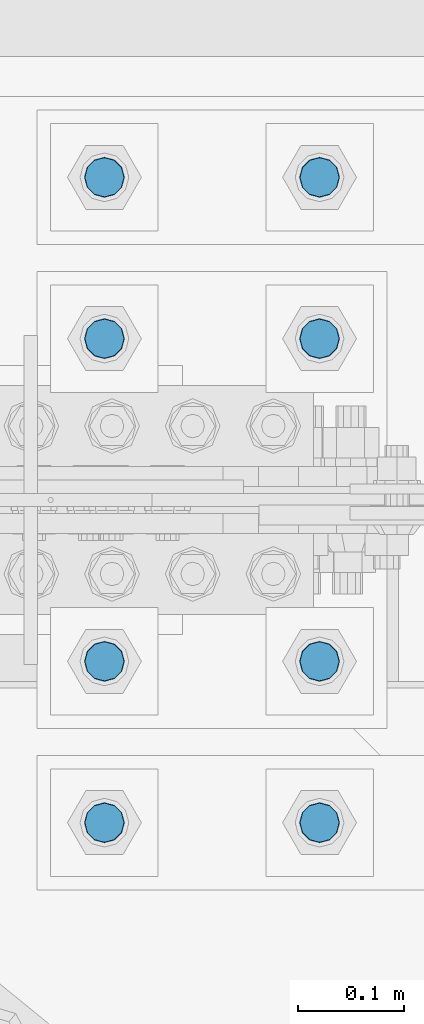
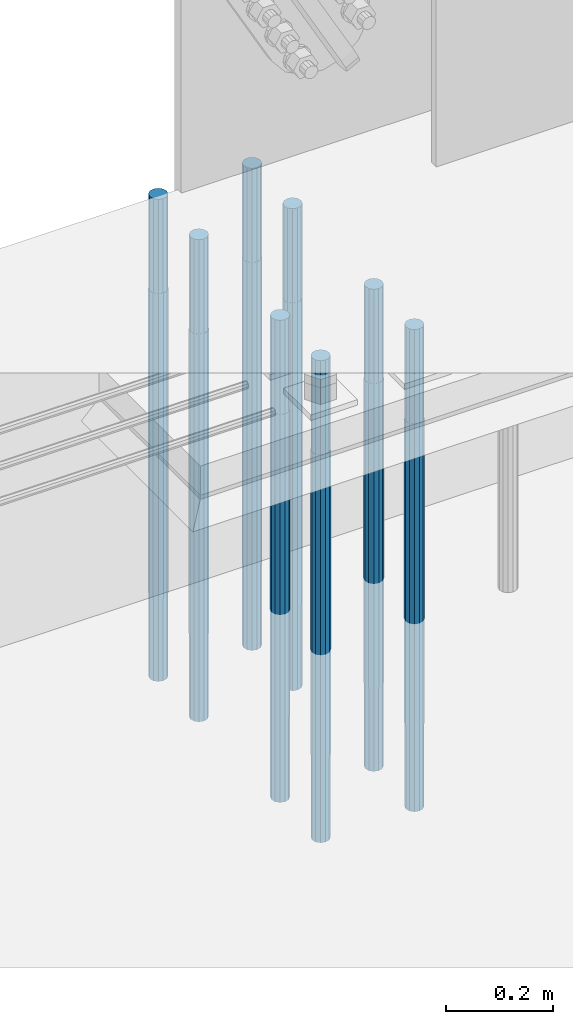
# One storey, part 1386 of 3843: 8 columns, 1 element without a shape of its own.
"""IFC2X3 building model written with IfcOpenShell, lengths in millimetres."""

from ifc_helpers import new_model, si_unit, frame, origin_with_axes, place, context, subcontext, project, spatial, faceted_brep, material, type_object, element, aggregate, save


model = new_model("IFC2X3")

# Units and contexts
model_context = context("Model", 3, precision=1e-05, world=origin_with_axes())
body_context = subcontext(model_context, "Body", "Model", "MODEL_VIEW")
ifc_project = project(units=[si_unit("LENGTHUNIT", "METRE", prefix="MILLI"), si_unit("AREAUNIT", "SQUARE_METRE"), si_unit("VOLUMEUNIT", "CUBIC_METRE"), si_unit("MASSUNIT", "GRAM", prefix="KILO"), si_unit("TIMEUNIT", "SECOND"), si_unit("PLANEANGLEUNIT", "RADIAN"), si_unit("SOLIDANGLEUNIT", "STERADIAN"), si_unit("THERMODYNAMICTEMPERATUREUNIT", "DEGREE_CELSIUS"), si_unit("LUMINOUSINTENSITYUNIT", "LUMEN")], contexts=[model_context])

# Site, building, storey
site_placement = place(None, origin_with_axes())
site = spatial("IfcSite", under=ifc_project, at=site_placement, CompositionType="ELEMENT")
building_placement = place(site_placement, origin_with_axes())
building = spatial("IfcBuilding", under=site, at=building_placement, Name="Undefined", CompositionType="ELEMENT")
storey_placement = place(building_placement, origin_with_axes())
storey = spatial("IfcBuildingStorey", under=building, at=storey_placement, Name="Undefined", CompositionType="ELEMENT", Elevation=0.0)

# Assembly, columns
assembly_placement = place(storey_placement, origin_with_axes())
assembly = element("IfcElementAssembly", 1, at=assembly_placement, inside=storey, Name="TEMPLATE", AssemblyPlace="NOTDEFINED", PredefinedType="RIGID_FRAME")
ifc_material = material(Name="Undefined/F1554-GR.55")
column_type = type_object("IfcColumnType", PredefinedType="NOTDEFINED")
column_1_placement = place(assembly_placement, frame((62128.4, 91909.9, 30022.8), z_axis=(0.0, -1.0, 0.0), x_axis=(0.0, 0.0, -1.0)))
column_1 = element("IfcColumn", 2, at=column_1_placement, type_object=column_type, material=ifc_material, Name="ANCHOR_ROD", context=body_context, shape_type="Brep", body=[
    faceted_brep([(-215.899999999998, -16.0214699700118, 9.25), (-215.899999999998, -9.25, 16.0214699700155), (-215.899999999998, 0.0, 18.5), (-215.899999999998, 9.25, 16.0214699700155), (-215.899999999998, 16.0214699700118, 9.25), (-215.899999999998, 18.5, 0.0), (-215.899999999998, 16.0214699700118, -9.25), (-215.899999999998, 9.25, -16.0214699700155), (-215.899999999998, 0.0, -18.5), (-215.899999999998, -9.25, -16.0214699700155), (-215.899999999998, -16.0214699700118, -9.25), (-215.899999999998, -18.5, 0.0), (0.0, 18.5, 0.0), (0.0, 16.0214699700118, -9.25), (0.0, 9.25, -16.0214699700155), (0.0, 0.0, -18.5), (0.0, -9.25, -16.0214699700155), (0.0, -16.0214699700118, -9.25), (0.0, -18.5, 0.0), (0.0, -16.0214699700118, 9.25), (0.0, -9.25, 16.0214699700155), (0.0, 0.0, 18.5), (0.0, 9.25, 16.0214699700155), (0.0, 16.0214699700118, 9.25), (0.0, -16.4977839420972, 9.52500000000146), (0.0, -9.52500000000146, 16.4977839420972), (0.0, 0.0, 19.0499989999989), (0.0, 9.52500000000146, 16.4977839420972), (0.0, 16.4977839420972, 9.52500000000146), (0.0, 19.0500000000029, 0.0), (0.0, 16.4977839420972, -9.52500000000146), (0.0, 9.52500000000146, -16.4977839420972), (0.0, 0.0, -19.0499989999989), (0.0, -9.52500000000146, -16.4977839420972), (0.0, -16.4977839420972, -9.52500000000146), (0.0, -19.0500000000029, 0.0), (698.5, -19.0499999999993, 0.0), (698.5, -16.4977839420935, 9.52499999999418), (698.5, -9.52500000000146, 16.4977839420899), (698.5, 0.0, 19.0500000000029), (698.5, 9.52500000000146, 16.4977839420899), (698.5, 16.4977839420935, 9.52499999999418), (698.5, 19.0499999999993, 0.0), (698.5, 16.4977839420935, -9.52499999999418), (698.5, 9.52500000000146, -16.4977839420899), (698.5, 0.0, -19.0500000000029), (698.5, -9.52500000000146, -16.4977839420899), (698.5, -16.4977839420935, -9.52499999999418), (698.5, -9.25, 16.0214699700155), (698.5, 0.0, 18.5), (698.5, 9.25, 16.0214699700155), (698.5, 16.0214699700118, 9.25), (698.5, 18.5, 0.0), (698.5, 16.0214699700118, -9.25), (698.5, 9.25, -16.0214699700155), (698.5, 0.0, -18.5), (698.5, -9.25, -16.0214699700155), (698.5, -16.0214699700118, -9.25), (698.5, -18.5, 0.0), (698.5, -16.0214699700118, 9.25), (889.0, -9.25, -16.0214699700155), (889.0, 0.0, -18.5), (889.0, 9.25, -16.0214699700155), (889.0, 16.0214699700118, -9.25), (889.0, 18.5, 0.0), (889.0, 16.0214699700118, 9.25), (889.0, 9.25, 16.0214699700155), (889.0, 0.0, 18.5), (889.0, -9.25, 16.0214699700155), (889.0, -16.0214699700118, 9.25), (889.0, -18.5, 0.0), (889.0, -16.0214699700118, -9.25)], [[[0, 1, 2, 3, 4, 5, 6, 7, 8, 9, 10, 11]], [[6, 5, 12, 13]], [[7, 6, 13, 14]], [[8, 7, 14, 15]], [[9, 8, 15, 16]], [[10, 9, 16, 17]], [[11, 10, 17, 18]], [[0, 11, 18, 19]], [[1, 0, 19, 20]], [[2, 1, 20, 21]], [[3, 2, 21, 22]], [[4, 3, 22, 23]], [[5, 4, 23, 12]], [[24, 25, 26, 27, 28, 29, 30, 31, 32, 33, 34, 35], [22, 21, 20, 19, 18, 17, 16, 15, 14, 13, 12, 23]], [[24, 35, 36, 37]], [[25, 24, 37, 38]], [[26, 25, 38, 39]], [[27, 26, 39, 40]], [[28, 27, 40, 41]], [[29, 28, 41, 42]], [[30, 29, 42, 43]], [[31, 30, 43, 44]], [[32, 31, 44, 45]], [[33, 32, 45, 46]], [[34, 33, 46, 47]], [[35, 34, 47, 36]], [[46, 45, 44, 43, 42, 41, 40, 39, 38, 37, 36, 47], [48, 49, 50, 51, 52, 53, 54, 55, 56, 57, 58, 59]], [[60, 61, 62, 63, 64, 65, 66, 67, 68, 69, 70, 71]], [[68, 67, 49, 48]], [[69, 68, 48, 59]], [[70, 69, 59, 58]], [[71, 70, 58, 57]], [[60, 71, 57, 56]], [[61, 60, 56, 55]], [[62, 61, 55, 54]], [[63, 62, 54, 53]], [[64, 63, 53, 52]], [[65, 64, 52, 51]], [[66, 65, 51, 50]], [[67, 66, 50, 49]]]),
])
column_2_placement = place(assembly_placement, frame((62331.6, 91909.9, 30022.8), z_axis=(0.0, -1.0, 0.0), x_axis=(0.0, 0.0, -1.0)))
column_2 = element("IfcColumn", 3, at=column_2_placement, type_object=column_type, material=ifc_material, Name="ANCHOR_ROD", context=body_context, shape_type="Brep", body=[
    faceted_brep([(-215.899999999998, -16.0214699700118, 9.25), (-215.899999999998, -9.25, 16.0214699700155), (-215.899999999998, 0.0, 18.5), (-215.899999999998, 9.25, 16.0214699700155), (-215.899999999998, 16.0214699700118, 9.25), (-215.899999999998, 18.5, 0.0), (-215.899999999998, 16.0214699700118, -9.25), (-215.899999999998, 9.25, -16.0214699700155), (-215.899999999998, 0.0, -18.5), (-215.899999999998, -9.25, -16.0214699700155), (-215.899999999998, -16.0214699700118, -9.25), (-215.899999999998, -18.5, 0.0), (0.0, 18.5, 0.0), (0.0, 16.0214699700118, -9.25), (0.0, 9.25, -16.0214699700155), (0.0, 0.0, -18.5), (0.0, -9.25, -16.0214699700155), (0.0, -16.0214699700118, -9.25), (0.0, -18.5, 0.0), (0.0, -16.0214699700118, 9.25), (0.0, -9.25, 16.0214699700155), (0.0, 0.0, 18.5), (0.0, 9.25, 16.0214699700155), (0.0, 16.0214699700118, 9.25), (0.0, -16.4977839420972, 9.52500000000146), (0.0, -9.52500000000146, 16.4977839420972), (0.0, 0.0, 19.0499989999989), (0.0, 9.52500000000146, 16.4977839420972), (0.0, 16.4977839420972, 9.52500000000146), (0.0, 19.0500000000029, 0.0), (0.0, 16.4977839420972, -9.52500000000146), (0.0, 9.52500000000146, -16.4977839420972), (0.0, 0.0, -19.0499989999989), (0.0, -9.52500000000146, -16.4977839420972), (0.0, -16.4977839420972, -9.52500000000146), (0.0, -19.0500000000029, 0.0), (698.5, -19.0499999999993, 0.0), (698.5, -16.4977839420935, 9.52499999999418), (698.5, -9.52500000000146, 16.4977839420899), (698.5, 0.0, 19.0500000000029), (698.5, 9.52500000000146, 16.4977839420899), (698.5, 16.4977839420935, 9.52499999999418), (698.5, 19.0499999999993, 0.0), (698.5, 16.4977839420935, -9.52499999999418), (698.5, 9.52500000000146, -16.4977839420899), (698.5, 0.0, -19.0500000000029), (698.5, -9.52500000000146, -16.4977839420899), (698.5, -16.4977839420935, -9.52499999999418), (698.5, -9.25, 16.0214699700155), (698.5, 0.0, 18.5), (698.5, 9.25, 16.0214699700155), (698.5, 16.0214699700118, 9.25), (698.5, 18.5, 0.0), (698.5, 16.0214699700118, -9.25), (698.5, 9.25, -16.0214699700155), (698.5, 0.0, -18.5), (698.5, -9.25, -16.0214699700155), (698.5, -16.0214699700118, -9.25), (698.5, -18.5, 0.0), (698.5, -16.0214699700118, 9.25), (889.0, -9.25, -16.0214699700155), (889.0, 0.0, -18.5), (889.0, 9.25, -16.0214699700155), (889.0, 16.0214699700118, -9.25), (889.0, 18.5, 0.0), (889.0, 16.0214699700118, 9.25), (889.0, 9.25, 16.0214699700155), (889.0, 0.0, 18.5), (889.0, -9.25, 16.0214699700155), (889.0, -16.0214699700118, 9.25), (889.0, -18.5, 0.0), (889.0, -16.0214699700118, -9.25)], [[[0, 1, 2, 3, 4, 5, 6, 7, 8, 9, 10, 11]], [[6, 5, 12, 13]], [[7, 6, 13, 14]], [[8, 7, 14, 15]], [[9, 8, 15, 16]], [[10, 9, 16, 17]], [[11, 10, 17, 18]], [[0, 11, 18, 19]], [[1, 0, 19, 20]], [[2, 1, 20, 21]], [[3, 2, 21, 22]], [[4, 3, 22, 23]], [[5, 4, 23, 12]], [[24, 25, 26, 27, 28, 29, 30, 31, 32, 33, 34, 35], [22, 21, 20, 19, 18, 17, 16, 15, 14, 13, 12, 23]], [[24, 35, 36, 37]], [[25, 24, 37, 38]], [[26, 25, 38, 39]], [[27, 26, 39, 40]], [[28, 27, 40, 41]], [[29, 28, 41, 42]], [[30, 29, 42, 43]], [[31, 30, 43, 44]], [[32, 31, 44, 45]], [[33, 32, 45, 46]], [[34, 33, 46, 47]], [[35, 34, 47, 36]], [[46, 45, 44, 43, 42, 41, 40, 39, 38, 37, 36, 47], [48, 49, 50, 51, 52, 53, 54, 55, 56, 57, 58, 59]], [[60, 61, 62, 63, 64, 65, 66, 67, 68, 69, 70, 71]], [[68, 67, 49, 48]], [[69, 68, 48, 59]], [[70, 69, 59, 58]], [[71, 70, 58, 57]], [[60, 71, 57, 56]], [[61, 60, 56, 55]], [[62, 61, 55, 54]], [[63, 62, 54, 53]], [[64, 63, 53, 52]], [[65, 64, 52, 51]], [[66, 65, 51, 50]], [[67, 66, 50, 49]]]),
])
column_3_placement = place(assembly_placement, frame((62128.4, 92062.3, 30022.8), z_axis=(0.0, -1.0, 0.0), x_axis=(0.0, 0.0, -1.0)))
column_3 = element("IfcColumn", 4, at=column_3_placement, type_object=column_type, material=ifc_material, Name="ANCHOR_ROD", context=body_context, shape_type="Brep", body=[
    faceted_brep([(-215.899999999998, -16.0214699700118, 9.25), (-215.899999999998, -9.25, 16.0214699700155), (-215.899999999998, 0.0, 18.5), (-215.899999999998, 9.25, 16.0214699700155), (-215.899999999998, 16.0214699700118, 9.25), (-215.899999999998, 18.5, 0.0), (-215.899999999998, 16.0214699700118, -9.25), (-215.899999999998, 9.25, -16.0214699700155), (-215.899999999998, 0.0, -18.5), (-215.899999999998, -9.25, -16.0214699700155), (-215.899999999998, -16.0214699700118, -9.25), (-215.899999999998, -18.5, 0.0), (0.0, 18.5, 0.0), (0.0, 16.0214699700118, -9.25), (0.0, 9.25, -16.0214699700155), (0.0, 0.0, -18.5), (0.0, -9.25, -16.0214699700155), (0.0, -16.0214699700118, -9.25), (0.0, -18.5, 0.0), (0.0, -16.0214699700118, 9.25), (0.0, -9.25, 16.0214699700155), (0.0, 0.0, 18.5), (0.0, 9.25, 16.0214699700155), (0.0, 16.0214699700118, 9.25), (0.0, -16.4977839420972, 9.52500000000146), (0.0, -9.52500000000146, 16.4977839420972), (0.0, 0.0, 19.0499989999989), (0.0, 9.52500000000146, 16.4977839420972), (0.0, 16.4977839420972, 9.52500000000146), (0.0, 19.0500000000029, 0.0), (0.0, 16.4977839420972, -9.52500000000146), (0.0, 9.52500000000146, -16.4977839420972), (0.0, 0.0, -19.0499989999989), (0.0, -9.52500000000146, -16.4977839420972), (0.0, -16.4977839420972, -9.52500000000146), (0.0, -19.0500000000029, 0.0), (698.5, -19.0499999999993, 0.0), (698.5, -16.4977839420935, 9.52499999999418), (698.5, -9.52500000000146, 16.4977839420899), (698.5, 0.0, 19.0500000000029), (698.5, 9.52500000000146, 16.4977839420899), (698.5, 16.4977839420935, 9.52499999999418), (698.5, 19.0499999999993, 0.0), (698.5, 16.4977839420935, -9.52499999999418), (698.5, 9.52500000000146, -16.4977839420899), (698.5, 0.0, -19.0500000000029), (698.5, -9.52500000000146, -16.4977839420899), (698.5, -16.4977839420935, -9.52499999999418), (698.5, -9.25, 16.0214699700155), (698.5, 0.0, 18.5), (698.5, 9.25, 16.0214699700155), (698.5, 16.0214699700118, 9.25), (698.5, 18.5, 0.0), (698.5, 16.0214699700118, -9.25), (698.5, 9.25, -16.0214699700155), (698.5, 0.0, -18.5), (698.5, -9.25, -16.0214699700155), (698.5, -16.0214699700118, -9.25), (698.5, -18.5, 0.0), (698.5, -16.0214699700118, 9.25), (889.0, -9.25, -16.0214699700155), (889.0, 0.0, -18.5), (889.0, 9.25, -16.0214699700155), (889.0, 16.0214699700118, -9.25), (889.0, 18.5, 0.0), (889.0, 16.0214699700118, 9.25), (889.0, 9.25, 16.0214699700155), (889.0, 0.0, 18.5), (889.0, -9.25, 16.0214699700155), (889.0, -16.0214699700118, 9.25), (889.0, -18.5, 0.0), (889.0, -16.0214699700118, -9.25)], [[[0, 1, 2, 3, 4, 5, 6, 7, 8, 9, 10, 11]], [[6, 5, 12, 13]], [[7, 6, 13, 14]], [[8, 7, 14, 15]], [[9, 8, 15, 16]], [[10, 9, 16, 17]], [[11, 10, 17, 18]], [[0, 11, 18, 19]], [[1, 0, 19, 20]], [[2, 1, 20, 21]], [[3, 2, 21, 22]], [[4, 3, 22, 23]], [[5, 4, 23, 12]], [[24, 25, 26, 27, 28, 29, 30, 31, 32, 33, 34, 35], [22, 21, 20, 19, 18, 17, 16, 15, 14, 13, 12, 23]], [[24, 35, 36, 37]], [[25, 24, 37, 38]], [[26, 25, 38, 39]], [[27, 26, 39, 40]], [[28, 27, 40, 41]], [[29, 28, 41, 42]], [[30, 29, 42, 43]], [[31, 30, 43, 44]], [[32, 31, 44, 45]], [[33, 32, 45, 46]], [[34, 33, 46, 47]], [[35, 34, 47, 36]], [[46, 45, 44, 43, 42, 41, 40, 39, 38, 37, 36, 47], [48, 49, 50, 51, 52, 53, 54, 55, 56, 57, 58, 59]], [[60, 61, 62, 63, 64, 65, 66, 67, 68, 69, 70, 71]], [[68, 67, 49, 48]], [[69, 68, 48, 59]], [[70, 69, 59, 58]], [[71, 70, 58, 57]], [[60, 71, 57, 56]], [[61, 60, 56, 55]], [[62, 61, 55, 54]], [[63, 62, 54, 53]], [[64, 63, 53, 52]], [[65, 64, 52, 51]], [[66, 65, 51, 50]], [[67, 66, 50, 49]]]),
])
column_4_placement = place(assembly_placement, frame((62331.6, 92062.3, 30022.8), z_axis=(0.0, -1.0, 0.0), x_axis=(0.0, 0.0, -1.0)))
column_4 = element("IfcColumn", 5, at=column_4_placement, type_object=column_type, material=ifc_material, Name="ANCHOR_ROD", context=body_context, shape_type="Brep", body=[
    faceted_brep([(-215.899999999998, -16.0214699700118, 9.25), (-215.899999999998, -9.25, 16.0214699700155), (-215.899999999998, 0.0, 18.5), (-215.899999999998, 9.25, 16.0214699700155), (-215.899999999998, 16.0214699700118, 9.25), (-215.899999999998, 18.5, 0.0), (-215.899999999998, 16.0214699700118, -9.25), (-215.899999999998, 9.25, -16.0214699700155), (-215.899999999998, 0.0, -18.5), (-215.899999999998, -9.25, -16.0214699700155), (-215.899999999998, -16.0214699700118, -9.25), (-215.899999999998, -18.5, 0.0), (0.0, 18.5, 0.0), (0.0, 16.0214699700118, -9.25), (0.0, 9.25, -16.0214699700155), (0.0, 0.0, -18.5), (0.0, -9.25, -16.0214699700155), (0.0, -16.0214699700118, -9.25), (0.0, -18.5, 0.0), (0.0, -16.0214699700118, 9.25), (0.0, -9.25, 16.0214699700155), (0.0, 0.0, 18.5), (0.0, 9.25, 16.0214699700155), (0.0, 16.0214699700118, 9.25), (0.0, -16.4977839420972, 9.52500000000146), (0.0, -9.52500000000146, 16.4977839420972), (0.0, 0.0, 19.0499989999989), (0.0, 9.52500000000146, 16.4977839420972), (0.0, 16.4977839420972, 9.52500000000146), (0.0, 19.0500000000029, 0.0), (0.0, 16.4977839420972, -9.52500000000146), (0.0, 9.52500000000146, -16.4977839420972), (0.0, 0.0, -19.0499989999989), (0.0, -9.52500000000146, -16.4977839420972), (0.0, -16.4977839420972, -9.52500000000146), (0.0, -19.0500000000029, 0.0), (698.5, -19.0499999999993, 0.0), (698.5, -16.4977839420935, 9.52499999999418), (698.5, -9.52500000000146, 16.4977839420899), (698.5, 0.0, 19.0500000000029), (698.5, 9.52500000000146, 16.4977839420899), (698.5, 16.4977839420935, 9.52499999999418), (698.5, 19.0499999999993, 0.0), (698.5, 16.4977839420935, -9.52499999999418), (698.5, 9.52500000000146, -16.4977839420899), (698.5, 0.0, -19.0500000000029), (698.5, -9.52500000000146, -16.4977839420899), (698.5, -16.4977839420935, -9.52499999999418), (698.5, -9.25, 16.0214699700155), (698.5, 0.0, 18.5), (698.5, 9.25, 16.0214699700155), (698.5, 16.0214699700118, 9.25), (698.5, 18.5, 0.0), (698.5, 16.0214699700118, -9.25), (698.5, 9.25, -16.0214699700155), (698.5, 0.0, -18.5), (698.5, -9.25, -16.0214699700155), (698.5, -16.0214699700118, -9.25), (698.5, -18.5, 0.0), (698.5, -16.0214699700118, 9.25), (889.0, -9.25, -16.0214699700155), (889.0, 0.0, -18.5), (889.0, 9.25, -16.0214699700155), (889.0, 16.0214699700118, -9.25), (889.0, 18.5, 0.0), (889.0, 16.0214699700118, 9.25), (889.0, 9.25, 16.0214699700155), (889.0, 0.0, 18.5), (889.0, -9.25, 16.0214699700155), (889.0, -16.0214699700118, 9.25), (889.0, -18.5, 0.0), (889.0, -16.0214699700118, -9.25)], [[[0, 1, 2, 3, 4, 5, 6, 7, 8, 9, 10, 11]], [[6, 5, 12, 13]], [[7, 6, 13, 14]], [[8, 7, 14, 15]], [[9, 8, 15, 16]], [[10, 9, 16, 17]], [[11, 10, 17, 18]], [[0, 11, 18, 19]], [[1, 0, 19, 20]], [[2, 1, 20, 21]], [[3, 2, 21, 22]], [[4, 3, 22, 23]], [[5, 4, 23, 12]], [[24, 25, 26, 27, 28, 29, 30, 31, 32, 33, 34, 35], [22, 21, 20, 19, 18, 17, 16, 15, 14, 13, 12, 23]], [[24, 35, 36, 37]], [[25, 24, 37, 38]], [[26, 25, 38, 39]], [[27, 26, 39, 40]], [[28, 27, 40, 41]], [[29, 28, 41, 42]], [[30, 29, 42, 43]], [[31, 30, 43, 44]], [[32, 31, 44, 45]], [[33, 32, 45, 46]], [[34, 33, 46, 47]], [[35, 34, 47, 36]], [[46, 45, 44, 43, 42, 41, 40, 39, 38, 37, 36, 47], [48, 49, 50, 51, 52, 53, 54, 55, 56, 57, 58, 59]], [[60, 61, 62, 63, 64, 65, 66, 67, 68, 69, 70, 71]], [[68, 67, 49, 48]], [[69, 68, 48, 59]], [[70, 69, 59, 58]], [[71, 70, 58, 57]], [[60, 71, 57, 56]], [[61, 60, 56, 55]], [[62, 61, 55, 54]], [[63, 62, 54, 53]], [[64, 63, 53, 52]], [[65, 64, 52, 51]], [[66, 65, 51, 50]], [[67, 66, 50, 49]]]),
])
column_5_placement = place(assembly_placement, frame((62128.4, 92367.1, 30022.8), z_axis=(0.0, -1.0, 0.0), x_axis=(0.0, 0.0, -1.0)))
column_5 = element("IfcColumn", 6, at=column_5_placement, type_object=column_type, material=ifc_material, Name="ANCHOR_ROD", context=body_context, shape_type="Brep", body=[
    faceted_brep([(-215.899999999998, -16.0214699700118, 9.25), (-215.899999999998, -9.25, 16.0214699700155), (-215.899999999998, 0.0, 18.5), (-215.899999999998, 9.25, 16.0214699700155), (-215.899999999998, 16.0214699700118, 9.25), (-215.899999999998, 18.5, 0.0), (-215.899999999998, 16.0214699700118, -9.25), (-215.899999999998, 9.25, -16.0214699700155), (-215.899999999998, 0.0, -18.5), (-215.899999999998, -9.25, -16.0214699700155), (-215.899999999998, -16.0214699700118, -9.25), (-215.899999999998, -18.5, 0.0), (0.0, 18.5, 0.0), (0.0, 16.0214699700118, -9.25), (0.0, 9.25, -16.0214699700155), (0.0, 0.0, -18.5), (0.0, -9.25, -16.0214699700155), (0.0, -16.0214699700118, -9.25), (0.0, -18.5, 0.0), (0.0, -16.0214699700118, 9.25), (0.0, -9.25, 16.0214699700155), (0.0, 0.0, 18.5), (0.0, 9.25, 16.0214699700155), (0.0, 16.0214699700118, 9.25), (0.0, -16.4977839420972, 9.52500000000146), (0.0, -9.52500000000146, 16.4977839420972), (0.0, 0.0, 19.0499989999989), (0.0, 9.52500000000146, 16.4977839420972), (0.0, 16.4977839420972, 9.52500000000146), (0.0, 19.0500000000029, 0.0), (0.0, 16.4977839420972, -9.52500000000146), (0.0, 9.52500000000146, -16.4977839420972), (0.0, 0.0, -19.0499989999989), (0.0, -9.52500000000146, -16.4977839420972), (0.0, -16.4977839420972, -9.52500000000146), (0.0, -19.0500000000029, 0.0), (698.5, -19.0499999999993, 0.0), (698.5, -16.4977839420935, 9.52499999999418), (698.5, -9.52500000000146, 16.4977839420899), (698.5, 0.0, 19.0500000000029), (698.5, 9.52500000000146, 16.4977839420899), (698.5, 16.4977839420935, 9.52499999999418), (698.5, 19.0499999999993, 0.0), (698.5, 16.4977839420935, -9.52499999999418), (698.5, 9.52500000000146, -16.4977839420899), (698.5, 0.0, -19.0500000000029), (698.5, -9.52500000000146, -16.4977839420899), (698.5, -16.4977839420935, -9.52499999999418), (698.5, -9.25, 16.0214699700155), (698.5, 0.0, 18.5), (698.5, 9.25, 16.0214699700155), (698.5, 16.0214699700118, 9.25), (698.5, 18.5, 0.0), (698.5, 16.0214699700118, -9.25), (698.5, 9.25, -16.0214699700155), (698.5, 0.0, -18.5), (698.5, -9.25, -16.0214699700155), (698.5, -16.0214699700118, -9.25), (698.5, -18.5, 0.0), (698.5, -16.0214699700118, 9.25), (889.0, -9.25, -16.0214699700155), (889.0, 0.0, -18.5), (889.0, 9.25, -16.0214699700155), (889.0, 16.0214699700118, -9.25), (889.0, 18.5, 0.0), (889.0, 16.0214699700118, 9.25), (889.0, 9.25, 16.0214699700155), (889.0, 0.0, 18.5), (889.0, -9.25, 16.0214699700155), (889.0, -16.0214699700118, 9.25), (889.0, -18.5, 0.0), (889.0, -16.0214699700118, -9.25)], [[[0, 1, 2, 3, 4, 5, 6, 7, 8, 9, 10, 11]], [[6, 5, 12, 13]], [[7, 6, 13, 14]], [[8, 7, 14, 15]], [[9, 8, 15, 16]], [[10, 9, 16, 17]], [[11, 10, 17, 18]], [[0, 11, 18, 19]], [[1, 0, 19, 20]], [[2, 1, 20, 21]], [[3, 2, 21, 22]], [[4, 3, 22, 23]], [[5, 4, 23, 12]], [[24, 25, 26, 27, 28, 29, 30, 31, 32, 33, 34, 35], [22, 21, 20, 19, 18, 17, 16, 15, 14, 13, 12, 23]], [[24, 35, 36, 37]], [[25, 24, 37, 38]], [[26, 25, 38, 39]], [[27, 26, 39, 40]], [[28, 27, 40, 41]], [[29, 28, 41, 42]], [[30, 29, 42, 43]], [[31, 30, 43, 44]], [[32, 31, 44, 45]], [[33, 32, 45, 46]], [[34, 33, 46, 47]], [[35, 34, 47, 36]], [[46, 45, 44, 43, 42, 41, 40, 39, 38, 37, 36, 47], [48, 49, 50, 51, 52, 53, 54, 55, 56, 57, 58, 59]], [[60, 61, 62, 63, 64, 65, 66, 67, 68, 69, 70, 71]], [[68, 67, 49, 48]], [[69, 68, 48, 59]], [[70, 69, 59, 58]], [[71, 70, 58, 57]], [[60, 71, 57, 56]], [[61, 60, 56, 55]], [[62, 61, 55, 54]], [[63, 62, 54, 53]], [[64, 63, 53, 52]], [[65, 64, 52, 51]], [[66, 65, 51, 50]], [[67, 66, 50, 49]]]),
])
column_6_placement = place(assembly_placement, frame((62331.6, 92367.1, 30022.8), z_axis=(0.0, -1.0, 0.0), x_axis=(0.0, 0.0, -1.0)))
column_6 = element("IfcColumn", 7, at=column_6_placement, type_object=column_type, material=ifc_material, Name="ANCHOR_ROD", context=body_context, shape_type="Brep", body=[
    faceted_brep([(-215.899999999998, -16.0214699700118, 9.25), (-215.899999999998, -9.25, 16.0214699700155), (-215.899999999998, 0.0, 18.5), (-215.899999999998, 9.25, 16.0214699700155), (-215.899999999998, 16.0214699700118, 9.25), (-215.899999999998, 18.5, 0.0), (-215.899999999998, 16.0214699700118, -9.25), (-215.899999999998, 9.25, -16.0214699700155), (-215.899999999998, 0.0, -18.5), (-215.899999999998, -9.25, -16.0214699700155), (-215.899999999998, -16.0214699700118, -9.25), (-215.899999999998, -18.5, 0.0), (0.0, 18.5, 0.0), (0.0, 16.0214699700118, -9.25), (0.0, 9.25, -16.0214699700155), (0.0, 0.0, -18.5), (0.0, -9.25, -16.0214699700155), (0.0, -16.0214699700118, -9.25), (0.0, -18.5, 0.0), (0.0, -16.0214699700118, 9.25), (0.0, -9.25, 16.0214699700155), (0.0, 0.0, 18.5), (0.0, 9.25, 16.0214699700155), (0.0, 16.0214699700118, 9.25), (0.0, -16.4977839420972, 9.52500000000146), (0.0, -9.52500000000146, 16.4977839420972), (0.0, 0.0, 19.0499989999989), (0.0, 9.52500000000146, 16.4977839420972), (0.0, 16.4977839420972, 9.52500000000146), (0.0, 19.0500000000029, 0.0), (0.0, 16.4977839420972, -9.52500000000146), (0.0, 9.52500000000146, -16.4977839420972), (0.0, 0.0, -19.0499989999989), (0.0, -9.52500000000146, -16.4977839420972), (0.0, -16.4977839420972, -9.52500000000146), (0.0, -19.0500000000029, 0.0), (698.5, -19.0499999999993, 0.0), (698.5, -16.4977839420935, 9.52499999999418), (698.5, -9.52500000000146, 16.4977839420899), (698.5, 0.0, 19.0500000000029), (698.5, 9.52500000000146, 16.4977839420899), (698.5, 16.4977839420935, 9.52499999999418), (698.5, 19.0499999999993, 0.0), (698.5, 16.4977839420935, -9.52499999999418), (698.5, 9.52500000000146, -16.4977839420899), (698.5, 0.0, -19.0500000000029), (698.5, -9.52500000000146, -16.4977839420899), (698.5, -16.4977839420935, -9.52499999999418), (698.5, -9.25, 16.0214699700155), (698.5, 0.0, 18.5), (698.5, 9.25, 16.0214699700155), (698.5, 16.0214699700118, 9.25), (698.5, 18.5, 0.0), (698.5, 16.0214699700118, -9.25), (698.5, 9.25, -16.0214699700155), (698.5, 0.0, -18.5), (698.5, -9.25, -16.0214699700155), (698.5, -16.0214699700118, -9.25), (698.5, -18.5, 0.0), (698.5, -16.0214699700118, 9.25), (889.0, -9.25, -16.0214699700155), (889.0, 0.0, -18.5), (889.0, 9.25, -16.0214699700155), (889.0, 16.0214699700118, -9.25), (889.0, 18.5, 0.0), (889.0, 16.0214699700118, 9.25), (889.0, 9.25, 16.0214699700155), (889.0, 0.0, 18.5), (889.0, -9.25, 16.0214699700155), (889.0, -16.0214699700118, 9.25), (889.0, -18.5, 0.0), (889.0, -16.0214699700118, -9.25)], [[[0, 1, 2, 3, 4, 5, 6, 7, 8, 9, 10, 11]], [[6, 5, 12, 13]], [[7, 6, 13, 14]], [[8, 7, 14, 15]], [[9, 8, 15, 16]], [[10, 9, 16, 17]], [[11, 10, 17, 18]], [[0, 11, 18, 19]], [[1, 0, 19, 20]], [[2, 1, 20, 21]], [[3, 2, 21, 22]], [[4, 3, 22, 23]], [[5, 4, 23, 12]], [[24, 25, 26, 27, 28, 29, 30, 31, 32, 33, 34, 35], [22, 21, 20, 19, 18, 17, 16, 15, 14, 13, 12, 23]], [[24, 35, 36, 37]], [[25, 24, 37, 38]], [[26, 25, 38, 39]], [[27, 26, 39, 40]], [[28, 27, 40, 41]], [[29, 28, 41, 42]], [[30, 29, 42, 43]], [[31, 30, 43, 44]], [[32, 31, 44, 45]], [[33, 32, 45, 46]], [[34, 33, 46, 47]], [[35, 34, 47, 36]], [[46, 45, 44, 43, 42, 41, 40, 39, 38, 37, 36, 47], [48, 49, 50, 51, 52, 53, 54, 55, 56, 57, 58, 59]], [[60, 61, 62, 63, 64, 65, 66, 67, 68, 69, 70, 71]], [[68, 67, 49, 48]], [[69, 68, 48, 59]], [[70, 69, 59, 58]], [[71, 70, 58, 57]], [[60, 71, 57, 56]], [[61, 60, 56, 55]], [[62, 61, 55, 54]], [[63, 62, 54, 53]], [[64, 63, 53, 52]], [[65, 64, 52, 51]], [[66, 65, 51, 50]], [[67, 66, 50, 49]]]),
])
column_7_placement = place(assembly_placement, frame((62128.4, 92519.5, 30022.8), z_axis=(0.0, -1.0, 0.0), x_axis=(0.0, 0.0, -1.0)))
column_7 = element("IfcColumn", 8, at=column_7_placement, type_object=column_type, material=ifc_material, Name="ANCHOR_ROD", context=body_context, shape_type="Brep", body=[
    faceted_brep([(-215.899999999998, -16.0214699700118, 9.25), (-215.899999999998, -9.25, 16.0214699700155), (-215.899999999998, 0.0, 18.5), (-215.899999999998, 9.25, 16.0214699700155), (-215.899999999998, 16.0214699700118, 9.25), (-215.899999999998, 18.5, 0.0), (-215.899999999998, 16.0214699700118, -9.25), (-215.899999999998, 9.25, -16.0214699700155), (-215.899999999998, 0.0, -18.5), (-215.899999999998, -9.25, -16.0214699700155), (-215.899999999998, -16.0214699700118, -9.25), (-215.899999999998, -18.5, 0.0), (0.0, 18.5, 0.0), (0.0, 16.0214699700118, -9.25), (0.0, 9.25, -16.0214699700155), (0.0, 0.0, -18.5), (0.0, -9.25, -16.0214699700155), (0.0, -16.0214699700118, -9.25), (0.0, -18.5, 0.0), (0.0, -16.0214699700118, 9.25), (0.0, -9.25, 16.0214699700155), (0.0, 0.0, 18.5), (0.0, 9.25, 16.0214699700155), (0.0, 16.0214699700118, 9.25), (0.0, -16.4977839420972, 9.52500000000146), (0.0, -9.52500000000146, 16.4977839420972), (0.0, 0.0, 19.0499989999989), (0.0, 9.52500000000146, 16.4977839420972), (0.0, 16.4977839420972, 9.52500000000146), (0.0, 19.0500000000029, 0.0), (0.0, 16.4977839420972, -9.52500000000146), (0.0, 9.52500000000146, -16.4977839420972), (0.0, 0.0, -19.0499989999989), (0.0, -9.52500000000146, -16.4977839420972), (0.0, -16.4977839420972, -9.52500000000146), (0.0, -19.0500000000029, 0.0), (698.5, -19.0499999999993, 0.0), (698.5, -16.4977839420935, 9.52499999999418), (698.5, -9.52500000000146, 16.4977839420899), (698.5, 0.0, 19.0500000000029), (698.5, 9.52500000000146, 16.4977839420899), (698.5, 16.4977839420935, 9.52499999999418), (698.5, 19.0499999999993, 0.0), (698.5, 16.4977839420935, -9.52499999999418), (698.5, 9.52500000000146, -16.4977839420899), (698.5, 0.0, -19.0500000000029), (698.5, -9.52500000000146, -16.4977839420899), (698.5, -16.4977839420935, -9.52499999999418), (698.5, -9.25, 16.0214699700155), (698.5, 0.0, 18.5), (698.5, 9.25, 16.0214699700155), (698.5, 16.0214699700118, 9.25), (698.5, 18.5, 0.0), (698.5, 16.0214699700118, -9.25), (698.5, 9.25, -16.0214699700155), (698.5, 0.0, -18.5), (698.5, -9.25, -16.0214699700155), (698.5, -16.0214699700118, -9.25), (698.5, -18.5, 0.0), (698.5, -16.0214699700118, 9.25), (889.0, -9.25, -16.0214699700155), (889.0, 0.0, -18.5), (889.0, 9.25, -16.0214699700155), (889.0, 16.0214699700118, -9.25), (889.0, 18.5, 0.0), (889.0, 16.0214699700118, 9.25), (889.0, 9.25, 16.0214699700155), (889.0, 0.0, 18.5), (889.0, -9.25, 16.0214699700155), (889.0, -16.0214699700118, 9.25), (889.0, -18.5, 0.0), (889.0, -16.0214699700118, -9.25)], [[[0, 1, 2, 3, 4, 5, 6, 7, 8, 9, 10, 11]], [[6, 5, 12, 13]], [[7, 6, 13, 14]], [[8, 7, 14, 15]], [[9, 8, 15, 16]], [[10, 9, 16, 17]], [[11, 10, 17, 18]], [[0, 11, 18, 19]], [[1, 0, 19, 20]], [[2, 1, 20, 21]], [[3, 2, 21, 22]], [[4, 3, 22, 23]], [[5, 4, 23, 12]], [[24, 25, 26, 27, 28, 29, 30, 31, 32, 33, 34, 35], [22, 21, 20, 19, 18, 17, 16, 15, 14, 13, 12, 23]], [[24, 35, 36, 37]], [[25, 24, 37, 38]], [[26, 25, 38, 39]], [[27, 26, 39, 40]], [[28, 27, 40, 41]], [[29, 28, 41, 42]], [[30, 29, 42, 43]], [[31, 30, 43, 44]], [[32, 31, 44, 45]], [[33, 32, 45, 46]], [[34, 33, 46, 47]], [[35, 34, 47, 36]], [[46, 45, 44, 43, 42, 41, 40, 39, 38, 37, 36, 47], [48, 49, 50, 51, 52, 53, 54, 55, 56, 57, 58, 59]], [[60, 61, 62, 63, 64, 65, 66, 67, 68, 69, 70, 71]], [[68, 67, 49, 48]], [[69, 68, 48, 59]], [[70, 69, 59, 58]], [[71, 70, 58, 57]], [[60, 71, 57, 56]], [[61, 60, 56, 55]], [[62, 61, 55, 54]], [[63, 62, 54, 53]], [[64, 63, 53, 52]], [[65, 64, 52, 51]], [[66, 65, 51, 50]], [[67, 66, 50, 49]]]),
])
column_8_placement = place(assembly_placement, frame((62331.6, 92519.5, 30022.8), z_axis=(0.0, -1.0, 0.0), x_axis=(0.0, 0.0, -1.0)))
column_8 = element("IfcColumn", 9, at=column_8_placement, type_object=column_type, material=ifc_material, Name="ANCHOR_ROD", context=body_context, shape_type="Brep", body=[
    faceted_brep([(-215.899999999998, -16.0214699700118, 9.25), (-215.899999999998, -9.25, 16.0214699700155), (-215.899999999998, 0.0, 18.5), (-215.899999999998, 9.25, 16.0214699700155), (-215.899999999998, 16.0214699700118, 9.25), (-215.899999999998, 18.5, 0.0), (-215.899999999998, 16.0214699700118, -9.25), (-215.899999999998, 9.25, -16.0214699700155), (-215.899999999998, 0.0, -18.5), (-215.899999999998, -9.25, -16.0214699700155), (-215.899999999998, -16.0214699700118, -9.25), (-215.899999999998, -18.5, 0.0), (0.0, 18.5, 0.0), (0.0, 16.0214699700118, -9.25), (0.0, 9.25, -16.0214699700155), (0.0, 0.0, -18.5), (0.0, -9.25, -16.0214699700155), (0.0, -16.0214699700118, -9.25), (0.0, -18.5, 0.0), (0.0, -16.0214699700118, 9.25), (0.0, -9.25, 16.0214699700155), (0.0, 0.0, 18.5), (0.0, 9.25, 16.0214699700155), (0.0, 16.0214699700118, 9.25), (0.0, -16.4977839420972, 9.52500000000146), (0.0, -9.52500000000146, 16.4977839420972), (0.0, 0.0, 19.0499989999989), (0.0, 9.52500000000146, 16.4977839420972), (0.0, 16.4977839420972, 9.52500000000146), (0.0, 19.0500000000029, 0.0), (0.0, 16.4977839420972, -9.52500000000146), (0.0, 9.52500000000146, -16.4977839420972), (0.0, 0.0, -19.0499989999989), (0.0, -9.52500000000146, -16.4977839420972), (0.0, -16.4977839420972, -9.52500000000146), (0.0, -19.0500000000029, 0.0), (698.5, -19.0499999999993, 0.0), (698.5, -16.4977839420935, 9.52499999999418), (698.5, -9.52500000000146, 16.4977839420899), (698.5, 0.0, 19.0500000000029), (698.5, 9.52500000000146, 16.4977839420899), (698.5, 16.4977839420935, 9.52499999999418), (698.5, 19.0499999999993, 0.0), (698.5, 16.4977839420935, -9.52499999999418), (698.5, 9.52500000000146, -16.4977839420899), (698.5, 0.0, -19.0500000000029), (698.5, -9.52500000000146, -16.4977839420899), (698.5, -16.4977839420935, -9.52499999999418), (698.5, -9.25, 16.0214699700155), (698.5, 0.0, 18.5), (698.5, 9.25, 16.0214699700155), (698.5, 16.0214699700118, 9.25), (698.5, 18.5, 0.0), (698.5, 16.0214699700118, -9.25), (698.5, 9.25, -16.0214699700155), (698.5, 0.0, -18.5), (698.5, -9.25, -16.0214699700155), (698.5, -16.0214699700118, -9.25), (698.5, -18.5, 0.0), (698.5, -16.0214699700118, 9.25), (889.0, -9.25, -16.0214699700155), (889.0, 0.0, -18.5), (889.0, 9.25, -16.0214699700155), (889.0, 16.0214699700118, -9.25), (889.0, 18.5, 0.0), (889.0, 16.0214699700118, 9.25), (889.0, 9.25, 16.0214699700155), (889.0, 0.0, 18.5), (889.0, -9.25, 16.0214699700155), (889.0, -16.0214699700118, 9.25), (889.0, -18.5, 0.0), (889.0, -16.0214699700118, -9.25)], [[[0, 1, 2, 3, 4, 5, 6, 7, 8, 9, 10, 11]], [[6, 5, 12, 13]], [[7, 6, 13, 14]], [[8, 7, 14, 15]], [[9, 8, 15, 16]], [[10, 9, 16, 17]], [[11, 10, 17, 18]], [[0, 11, 18, 19]], [[1, 0, 19, 20]], [[2, 1, 20, 21]], [[3, 2, 21, 22]], [[4, 3, 22, 23]], [[5, 4, 23, 12]], [[24, 25, 26, 27, 28, 29, 30, 31, 32, 33, 34, 35], [22, 21, 20, 19, 18, 17, 16, 15, 14, 13, 12, 23]], [[24, 35, 36, 37]], [[25, 24, 37, 38]], [[26, 25, 38, 39]], [[27, 26, 39, 40]], [[28, 27, 40, 41]], [[29, 28, 41, 42]], [[30, 29, 42, 43]], [[31, 30, 43, 44]], [[32, 31, 44, 45]], [[33, 32, 45, 46]], [[34, 33, 46, 47]], [[35, 34, 47, 36]], [[46, 45, 44, 43, 42, 41, 40, 39, 38, 37, 36, 47], [48, 49, 50, 51, 52, 53, 54, 55, 56, 57, 58, 59]], [[60, 61, 62, 63, 64, 65, 66, 67, 68, 69, 70, 71]], [[68, 67, 49, 48]], [[69, 68, 48, 59]], [[70, 69, 59, 58]], [[71, 70, 58, 57]], [[60, 71, 57, 56]], [[61, 60, 56, 55]], [[62, 61, 55, 54]], [[63, 62, 54, 53]], [[64, 63, 53, 52]], [[65, 64, 52, 51]], [[66, 65, 51, 50]], [[67, 66, 50, 49]]]),
])
aggregate(assembly, [column_1, column_2, column_3, column_4, column_5, column_6, column_7, column_8])

save(model, "model.ifc")
